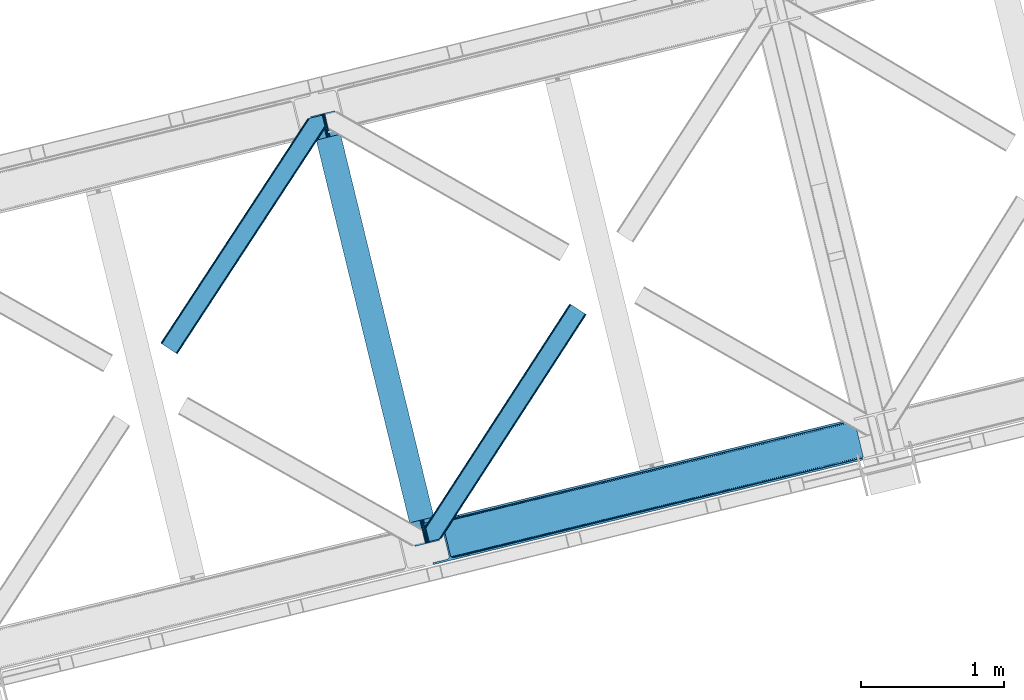
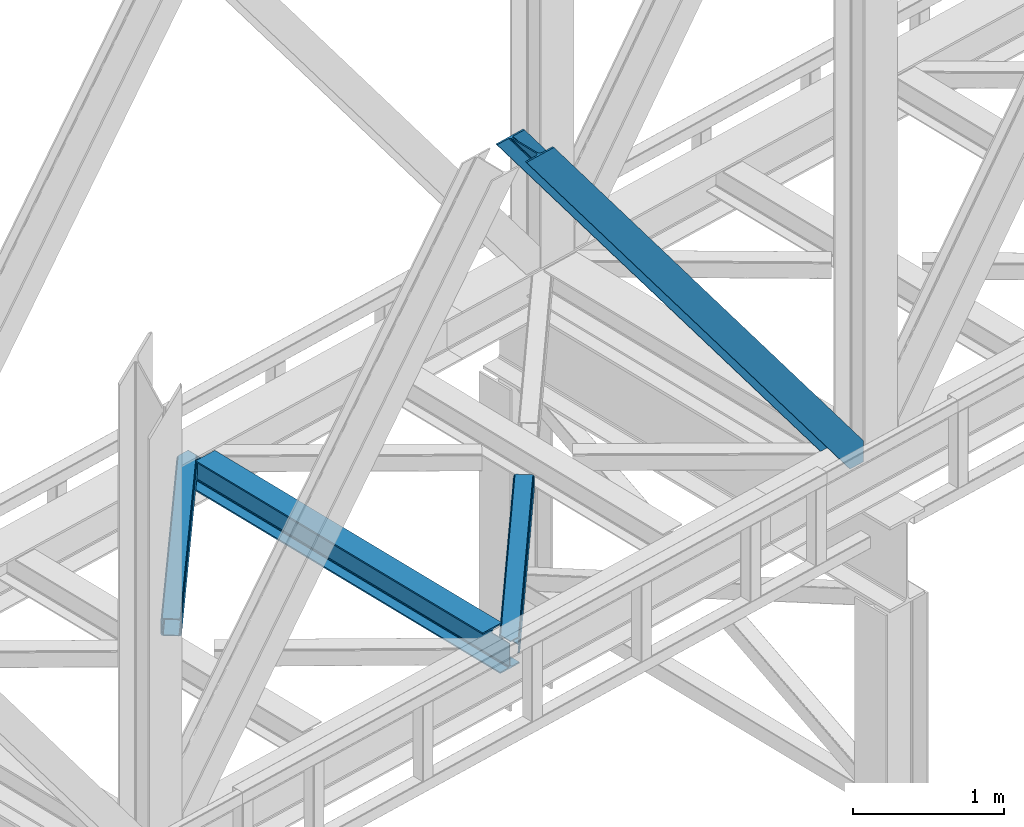
# One storey, part 54 of 92: 3 members, 1 beam.
"""IFC4 building model written with IfcOpenShell, lengths in millimetres."""

from ifc_helpers import new_model, entity, si_unit, converted_unit, derived_unit, direction, frame, origin, place, context, subcontext, project, spatial, triangles, polygons, material, type_object, element, save


model = new_model("IFC4")

# Units and contexts
model_context = context("Model", 3, precision=0.01, world=origin(), true_north=direction((6.12303176911189e-17, 1.0)))
plan_context = context("Plan", 3, precision=0.01, world=origin(), true_north=direction((6.12303176911189e-17, 1.0)))
body_context = subcontext(model_context, "Body", "Model", "MODEL_VIEW")
ifc_project = project(units=[si_unit("LENGTHUNIT", "METRE", prefix="MILLI"), si_unit("AREAUNIT", "SQUARE_METRE"), si_unit("VOLUMEUNIT", "CUBIC_METRE"), converted_unit("PLANEANGLEUNIT", "DEGREE", entity("IfcRatioMeasure", 0.0174532925199433), si_unit("PLANEANGLEUNIT", "RADIAN"), dimensions=[0, 0, 0, 0, 0, 0, 0]), si_unit("MASSUNIT", "GRAM", prefix="KILO"), derived_unit("MASSDENSITYUNIT", [(si_unit("MASSUNIT", "GRAM", prefix="KILO"), 1), (si_unit("LENGTHUNIT", "METRE"), -3)]), derived_unit("MOMENTOFINERTIAUNIT", [(si_unit("LENGTHUNIT", "METRE"), 4)]), si_unit("TIMEUNIT", "SECOND"), si_unit("FREQUENCYUNIT", "HERTZ"), si_unit("THERMODYNAMICTEMPERATUREUNIT", "DEGREE_CELSIUS"), derived_unit("THERMALTRANSMITTANCEUNIT", [(si_unit("MASSUNIT", "GRAM", prefix="KILO"), 1), (si_unit("THERMODYNAMICTEMPERATUREUNIT", "KELVIN"), -1), (si_unit("TIMEUNIT", "SECOND"), -3)]), derived_unit("VOLUMETRICFLOWRATEUNIT", [(si_unit("LENGTHUNIT", "METRE"), 3), (si_unit("TIMEUNIT", "SECOND"), -1)]), derived_unit("MASSFLOWRATEUNIT", [(si_unit("MASSUNIT", "GRAM", prefix="KILO"), 1), (si_unit("TIMEUNIT", "SECOND"), -1)]), derived_unit("ROTATIONALFREQUENCYUNIT", [(si_unit("TIMEUNIT", "SECOND"), -1)]), si_unit("ELECTRICCURRENTUNIT", "AMPERE"), si_unit("ELECTRICVOLTAGEUNIT", "VOLT"), si_unit("POWERUNIT", "WATT"), si_unit("FORCEUNIT", "NEWTON", prefix="KILO"), si_unit("ILLUMINANCEUNIT", "LUX"), si_unit("LUMINOUSFLUXUNIT", "LUMEN"), si_unit("LUMINOUSINTENSITYUNIT", "CANDELA"), derived_unit("USERDEFINED", [(si_unit("MASSUNIT", "GRAM", prefix="KILO"), -1), (si_unit("LENGTHUNIT", "METRE"), -2), (si_unit("TIMEUNIT", "SECOND"), 3), (si_unit("LUMINOUSFLUXUNIT", "LUMEN"), 1)]), derived_unit("LINEARVELOCITYUNIT", [(si_unit("LENGTHUNIT", "METRE"), 1), (si_unit("TIMEUNIT", "SECOND"), -1)]), si_unit("PRESSUREUNIT", "PASCAL"), derived_unit("USERDEFINED", [(si_unit("LENGTHUNIT", "METRE"), -2), (si_unit("MASSUNIT", "GRAM", prefix="KILO"), 1), (si_unit("TIMEUNIT", "SECOND"), -2)]), derived_unit("LINEARFORCEUNIT", [(si_unit("MASSUNIT", "GRAM", prefix="KILO"), 1), (si_unit("LENGTHUNIT", "METRE"), 1), (si_unit("TIMEUNIT", "SECOND"), -2), (si_unit("LENGTHUNIT", "METRE"), -1)]), derived_unit("PLANARFORCEUNIT", [(si_unit("MASSUNIT", "GRAM", prefix="KILO"), 1), (si_unit("LENGTHUNIT", "METRE"), 1), (si_unit("TIMEUNIT", "SECOND"), -2), (si_unit("LENGTHUNIT", "METRE"), -2)])], contexts=[model_context, plan_context])

# Site, building, storey
site_placement = place(None, origin())
site = spatial("IfcSite", under=ifc_project, at=site_placement, CompositionType="ELEMENT")
building_placement = place(site_placement, origin())
building = spatial("IfcBuilding", under=site, at=building_placement, CompositionType="ELEMENT")
storey_placement = place(building_placement, frame((0.0, 0.0, 15900.0)))
storey = spatial("IfcBuildingStorey", under=building, at=storey_placement, Name="05", CompositionType="ELEMENT", Elevation=15900.0)

# Beam
ifc_material = material(Name="Metal painted (White)")
beam_type = type_object("IfcBeamType", PredefinedType="BEAM")
beam_placement = place(storey_placement, frame((-33403.98, 9644.13, 3441.0)))
element("IfcBeam", 1, at=beam_placement, inside=storey, type_object=beam_type, material=ifc_material, ObjectType="Steel Beam", PredefinedType="BEAM", context=body_context, shape_type="Tessellation", body=[
    polygons([(900.98534618944, 41.4445662733092, 11.000000000004), (900.98534618944, 41.4445662733092, 2.16573425859679e-12), (170.021610174761, 3040.13999372697, 2.16573425859679e-12), (170.021610174761, 3040.13999372697, 11.000000000004), (834.919806235814, 25.3403919499667, 11.000000000004), (103.956070221144, 3024.03581940363, 11.000000000004), (828.971056214522, 23.8903211957407, 12.2179274798217), (98.0073201998513, 3022.5857486494, 12.2179274798217), (823.927949458409, 22.6610105689183, 15.6862915010235), (92.964213443734, 3021.35643802258, 15.6862915010235), (820.558253255237, 21.8396114687119, 20.8770650821657), (89.5945172405668, 3020.53503892237, 20.8770650821657), (819.374973305552, 21.5511744621206, 27.0000000000047), (88.4112372908723, 3020.24660191578, 27.0000000000047), (81.6103728838844, 3018.58881926485, 27.0000000000025), (81.6103728838801, 3018.58881926485, 203.000000000006), (88.4112372908723, 3020.24660191578, 203.000000000006), (0.0, 2998.69542745366, 2.16573425859679e-12), (0.0, 2998.69542745366, 10.9999999999997), (66.0655399536216, 3014.799601777, 11.000000000004), (72.014289974914, 3016.24967253123, 12.2179274798217), (77.0573967310226, 3017.47898315805, 15.6862915010192), (80.4270929342029, 3018.30038225826, 20.8770650821657), (819.374973305552, 21.5511744621206, 203.000000000006), (812.574108898559, 19.8933918111876, 203.000000000006), (812.574108898559, 19.8933918111876, 27.0000000000025), (811.390828948882, 19.6049548045984, 20.8770650821657), (808.021132745702, 18.7835557043887, 15.6862915010192), (802.978025989593, 17.5542450775685, 12.2179274798217), (797.029275968301, 16.1041743233436, 11.000000000004), (730.963736014679, 0.0, 10.9999999999997), (730.963736014679, 0.0, 2.16573425859679e-12), (779.675212882766, 184.415062601693, 203.069791966819), (128.020401343512, 2857.75452019162, 203.000000000006), (128.243282132663, 2856.8401777572, 203.617301946336), (128.256196377186, 2856.7871977843, 217.000003693143), (779.530009633837, 185.010597404073, 217.000003676718), (779.530880241731, 185.007025963196, 204.00000679514), (772.96491171832, 182.385463974442, 203.006342981529), (772.742064056782, 183.299815969777, 203.617301946336), (772.729149812254, 183.352795942668, 217.000003693143), (121.455336555608, 2855.1293963229, 217.000003676718), (121.454465947714, 2855.13296776377, 204.00000679514), (121.31016635866, 2855.72494066435, 203.076120467494), (121.219536936524, 2856.09673754069, 203.000000000006), (780.713494357868, 185.298194377515, 223.122939328039), (784.082490766539, 186.122464201392, 228.313710402595), (789.125126170563, 187.353708426698, 231.782072735464), (795.073705041271, 188.804481281382, 232.999999602236), (861.139155906794, 204.909021065316, 232.999999283132), (861.137682570357, 204.915065042189, 243.999994005812), (691.11630166644, 163.469558245299, 243.999994827032), (691.117775002877, 163.463514268425, 233.000000104353), (757.183225868401, 179.568054052362, 232.999999785253), (763.132130996726, 181.017488520583, 231.782072861016), (768.175695503862, 182.244921343717, 228.313710479427), (771.546082413602, 183.063487001149, 223.12293937232), (120.271851831576, 2854.84179934946, 223.122939328039), (116.902855422897, 2854.01752952558, 228.313710402595), (111.860220018877, 2852.78628530027, 231.782072735464), (105.911641148165, 2851.33551244559, 232.999999602236), (39.8461902826505, 2835.23097266165, 232.999999283128), (39.8476636190881, 2835.22492868478, 243.999994005812), (209.869044523005, 2876.67043548167, 243.999994827032), (209.867571186567, 2876.67647945855, 233.000000104357), (143.80212032104, 2860.57193967461, 232.999999785253), (137.85321519271, 2859.12250520639, 231.782072861012), (132.809650685579, 2857.89507238325, 228.313710479427), (129.439263775838, 2857.07650672582, 223.12293937232)], [[[1, 2, 3, 4]], [[5, 1, 4, 6]], [[7, 5, 6, 8]], [[9, 7, 8, 10]], [[11, 9, 10, 12]], [[13, 11, 12, 14]], [[15, 16, 17, 14, 12, 10, 8, 6, 4, 3, 18, 19, 20, 21, 22, 23]], [[13, 24, 25, 26, 27, 28, 29, 30, 31, 32, 2, 1, 5, 7, 9, 11]], [[2, 32, 18, 3]], [[32, 31, 19, 18]], [[31, 30, 20, 19]], [[27, 26, 15, 23]], [[28, 27, 23, 22]], [[29, 28, 22, 21]], [[30, 29, 21, 20]], [[33, 24, 13, 14, 17, 34, 35, 36, 37, 38]], [[25, 39, 40, 41, 42, 43, 44, 16, 15, 26]], [[39, 25, 24, 33]], [[45, 34, 17, 16]], [[41, 40, 38, 37, 46, 47, 48, 49, 50, 51, 52, 53, 54, 55, 56, 57]], [[42, 58, 59, 60, 61, 62, 63, 64, 65, 66, 67, 68, 69, 36, 35, 43]], [[46, 37, 36, 69]], [[47, 46, 69, 68]], [[48, 47, 68, 67]], [[49, 48, 67, 66]], [[50, 49, 66, 65]], [[51, 50, 65, 64]], [[52, 51, 64, 63]], [[53, 52, 63, 62]], [[54, 53, 62, 61]], [[55, 54, 61, 60]], [[56, 55, 60, 59]], [[57, 56, 59, 58]], [[41, 57, 58, 42]]], closed=False),
])

# Members
member_type_1 = type_object("IfcMemberType", PredefinedType="BRACE")
member_1_placement = place(storey_placement, frame((-32615.9, 9516.32, 3695.0)))
element("IfcMember", 2, at=member_1_placement, inside=storey, type_object=member_type_1, ObjectType="Steel Vertical Brace", PredefinedType="BRACE", context=body_context, shape_type="Tessellation", body=[
    triangles([(3070.87069702148, 756.345112609863, 0.827856445310317), (3071.52647094726, 755.357963562012, 1.13481445312209), (3070.10562744141, 754.873109436036, 0.0), (3068.17783813476, 762.778440856933, 0.0), (3067.78251342773, 753.546446228027, 7.26932373046657), (3067.78251342773, 753.546446228027, 0.0), (3064.92454833984, 750.387336730957, 0.0), (3063.48277587891, 746.379441833496, 0.0), (3065.2245300293, 750.173396301268, 14.9735046386704), (3064.09204101563, 748.68162689209, 18.377947998044), (3063.67113647461, 742.123887634278, 0.0), (3063.35952758789, 744.487696838378, 30.2981506347642), (3063.478125, 743.106385803223, 41.9881347656228), (3063.68508911133, 746.345722961425, 25.0194030761704), (3063.478125, 743.106385803223, 170.743066406249), (3063.67113647461, 742.123887634278, 170.803527832031), (215.791479492189, 48.9522445678704, 3911.00081176758), (310.560113525389, 72.0531600952145, 3911.00081176758), (192.892877197264, 54.8071197509762, 3911.00081176758), (199.032037353514, 50.2928604125973, 3911.00081176758), (207.07108154297, 48.2371719360344, 3911.00081176758), (189.588427734376, 61.0922012329102, 3911.00081176758), (3066.51282348633, 730.465296936034, 170.803527832031), (313.638995361329, 59.4225357055657, 3911.00081176758), (3066.51282348633, 730.465296936034, 0.0), (2948.45258789062, 701.686820983887, 0.0), (69.8631774902351, 0.0, 3911.00081176758), (2945.37370605469, 714.317445373536, 0.0), (66.7842956542954, 12.6300430297852, 3911.00081176758), (161.552929687499, 35.7309585571293, 3911.00081176758), (3040.14001464844, 737.417198181152, 0.0), (3057.81800537109, 760.25301361084, 0.0), (3057.77847290039, 753.153446960448, 0.0), (179.230920410155, 58.5667739868168, 3911.00081176758), (179.191387939452, 51.4677886962891, 3911.00081176758), (3054.40658569336, 746.321305847168, 0.0), (175.819500732421, 44.6350662231434, 3911.00081176758), (3048.21394042969, 740.794898986816, 0.0), (169.624530029298, 39.1086593627933, 3911.00081176758), (3002.63765258789, 986.625242614746, 0.0), (124.050567626953, 284.939002990723, 3911.00081176758), (2976.43460083008, 998.764036560058, 0.0), (2985.15732421875, 999.480271911621, 0.0), (106.567913818359, 297.794032287597, 3911.00081176758), (97.8475158691399, 297.078959655761, 3911.00081176758), (2993.1963684082, 997.424583435059, 0.0), (114.609283447266, 295.738343811036, 3911.00081176758), (2999.33552856445, 992.909742736816, 0.0), (120.748443603516, 291.223503112793, 3911.00081176758), (3.07888183593604, 273.978044128418, 3911.00081176758), (2881.66829223633, 975.664283752441, 0.0), (2878.58941040039, 988.29490814209, 0.0), (0.0, 286.60750579834, 3911.00081176758), (3012.99748535156, 989.150669860839, 0.0), (134.40807495117, 287.463267517089, 3911.00081176758), (144.014465332031, 306.922544860839, 3911.00081176758), (243.775817871094, 346.030622863769, 3911.00081176758), (152.08606567383, 310.300245666504, 3911.00081176758), (137.821820068359, 301.396138000488, 3911.00081176758), (134.449932861327, 294.563996887207, 3911.00081176758), (246.85469970703, 333.39999847412, 3911.00081176758), (2996.64964599609, 1017.07222137451, 170.803527832031), (2996.64964599609, 1017.07222137451, 0.0), (2999.49133300781, 1005.41363067627, 170.803527832031), (2999.77271118164, 1004.45322418213, 170.743066406249), (2999.77271118164, 1004.45322418213, 41.9881347656228), (2999.49133300781, 1005.41363067627, 0.0), (3008.39776611328, 997.164134216308, 0.0), (3001.28192138672, 1001.54875030518, 0.0), (3004.40731201172, 998.654740905762, 0.0), (3011.07202148438, 997.056001281739, 0.0), (3000.30291137695, 1003.17190704346, 30.2981506347642), (3001.44702758789, 1001.67199859619, 25.0194030761704), (3002.88182373047, 999.78490447998, 18.377947998044), (3004.57474365235, 998.981465148925, 14.9735046386704), (3008.39776611328, 997.164134216308, 7.26932373046657), (3012.55565185547, 997.279243469238, 1.13481445312209), (3012.42775268555, 996.10140838623, 0.827856445310317)], [[1, 2, 3], [3, 4, 1], [5, 6, 3], [7, 6, 5], [8, 7, 9], [9, 10, 8], [11, 12, 13], [11, 8, 14], [14, 12, 11], [13, 15, 16], [16, 11, 13], [10, 14, 8], [5, 9, 7], [3, 2, 5], [17, 18, 15], [15, 13, 17], [1, 19, 5], [19, 20, 10], [10, 9, 19], [9, 5, 19], [13, 12, 21], [21, 17, 13], [14, 20, 12], [14, 10, 20], [20, 21, 12], [5, 2, 1], [1, 4, 19], [22, 19, 4], [16, 15, 18], [23, 16, 24], [18, 24, 16], [23, 25, 16], [11, 16, 25], [24, 26, 23], [24, 27, 26], [26, 25, 23], [28, 26, 27], [27, 29, 28], [29, 30, 28], [31, 28, 30], [32, 33, 34], [35, 34, 33], [33, 36, 35], [37, 35, 36], [36, 38, 37], [39, 37, 38], [38, 31, 39], [30, 39, 31], [40, 32, 34], [34, 41, 40], [42, 43, 44], [44, 45, 42], [43, 46, 47], [47, 44, 43], [46, 48, 49], [49, 47, 46], [48, 40, 41], [41, 49, 48], [45, 50, 51], [51, 42, 45], [52, 51, 50], [50, 53, 52], [4, 54, 22], [55, 22, 54], [41, 34, 55], [37, 39, 21], [30, 27, 24], [29, 27, 30], [39, 30, 17], [34, 35, 19], [35, 37, 20], [47, 56, 44], [53, 45, 57], [45, 44, 58], [53, 50, 45], [47, 49, 59], [49, 41, 60], [55, 34, 22], [17, 21, 39], [19, 35, 20], [21, 20, 37], [19, 22, 34], [24, 17, 30], [24, 18, 17], [58, 44, 56], [59, 49, 60], [55, 60, 41], [59, 56, 47], [58, 57, 45], [57, 58, 61], [57, 52, 53], [52, 57, 62], [63, 52, 62], [64, 62, 57], [65, 64, 61], [57, 61, 64], [61, 58, 65], [66, 65, 58], [64, 67, 63], [63, 62, 64], [32, 40, 54], [46, 43, 67], [42, 52, 63], [51, 52, 42], [43, 42, 63], [40, 48, 68], [48, 46, 69], [36, 11, 38], [26, 31, 25], [31, 38, 25], [26, 28, 31], [36, 33, 8], [33, 32, 6], [8, 11, 36], [54, 40, 68], [67, 69, 46], [63, 67, 43], [48, 69, 70], [70, 68, 48], [71, 54, 68], [32, 54, 4], [8, 33, 7], [33, 6, 7], [11, 25, 38], [32, 4, 6], [3, 6, 4], [67, 72, 73], [65, 66, 64], [67, 64, 66], [66, 72, 67], [69, 74, 75], [69, 73, 74], [70, 75, 76], [76, 77, 71], [71, 68, 76], [76, 68, 70], [75, 70, 69], [73, 69, 67], [60, 78, 76], [76, 59, 60], [76, 75, 59], [74, 59, 75], [78, 77, 76], [54, 78, 60], [60, 55, 54], [73, 59, 74], [59, 73, 72], [56, 59, 72], [72, 66, 56], [58, 56, 66], [77, 78, 71], [54, 71, 78]]),
])
member_type_2 = type_object("IfcMemberType", PredefinedType="BRACE")
member_2_placement = place(storey_placement, frame((-34450.78, 10986.08, 3511.0)))
element("IfcMember", 3, at=member_2_placement, inside=storey, type_object=member_type_2, ObjectType="Steel Horizontal Brace", PredefinedType="BRACE", context=body_context, shape_type="Tessellation", body=[
    triangles([(994.774163818358, 1564.02778930664, 0.0), (1028.82324829101, 1424.34794311523, 0.0), (14.6409667968692, 67.1040435791019, 0.0), (102.486767578121, 9.58662414550781, 0.0), (1.11388549804542, 75.9604797363281, 10.8028289794929), (0.0, 76.6906677246097, 17.5000946044929), (1025.02813110351, 1642.17999572754, 17.5000946044929), (4.28811035156104, 73.8826995849613, 5.12526855468968), (990.476751708979, 1585.8776184082, 9.50058288574292), (990.04654541015, 1584.44747314453, 8.74132690429906), (989.907019042963, 1583.99284973144, 8.50064392089917), (990.762780761717, 1580.48841247559, 5.12526855468968), (1027.30938720703, 1642.73577575684, 10.8702667236357), (1027.78145141601, 1642.85088500977, 9.50058288574292), (992.602203369141, 1572.93654785156, 1.33247680664135), (9.03898315429251, 70.7724243164066, 1.33247680664135), (1025.02813110351, 1642.17999572754, 122.500662231447), (0.0, 76.6906677246097, 122.500662231447), (1026.92103881836, 1642.64159545898, 129.197927856447), (1.11388549804542, 75.9604797363281, 129.197927856447), (1032.31605834961, 1643.95663146973, 134.874325561526), (4.28811035156104, 73.8826995849613, 134.874325561526), (1040.39463500976, 1645.9251159668, 138.667117309571), (9.03898315429251, 70.7724243164066, 138.667117309571), (1049.91963500976, 1648.24706726074, 139.999594116212), (14.6409667968692, 67.1040435791019, 139.999594116212), (994.871832275385, 1567.8519744873, 9.50058288574292), (994.762536621092, 1567.00783996582, 9.29478149414354), (994.648590087891, 1566.15091552734, 9.08781738281323), (994.541619873045, 1565.30678100586, 8.8831787109375), (994.746258544918, 1564.14522399902, 8.50064392089917), (1047.05469360351, 1647.54827270508, 9.50058288574292), (14.8944396972656, 66.9377746582031, 8.3320495605476), (20.4987487792969, 63.2705566406257, 6.99957275390625), (997.043792724609, 1554.7155670166, 6.99957275390625), (10.1458923339815, 70.0480499267578, 12.1260040283232), (1042.27359008789, 1646.38322753906, 12.1260040283232), (1036.87857055664, 1645.06819152832, 17.8035644531265), (1034.98333740234, 1644.60659179688, 24.4996673583992), (6.96934204101126, 72.1258300781246, 17.8035644531265), (5.85545654296584, 72.8560180664063, 24.4996673583992), (1026.55361938477, 1433.66016540527, 6.99957275390625), (96.6289855957002, 13.4212738037113, 6.99957275390625), (1028.71860351562, 1424.77698669434, 8.41343994140698), (1032.83463134765, 1407.88615722656, 5.12526855468968), (1033.6903930664, 1404.38288269043, 8.50064392089917), (1030.99520874023, 1415.43918457031, 1.33247680664135), (1034.98333740234, 1644.60659179688, 115.501089477541), (5.85545654296584, 72.8560180664063, 115.501089477541), (1050.34751586914, 1648.35171203613, 131.667544555665), (1059.87251586914, 1650.67366333008, 133.000021362306), (20.4987487792969, 63.2705566406257, 133.000021362306), (14.8944396972656, 66.9377746582031, 131.667544555665), (1042.27359008789, 1646.38322753906, 127.87475280762), (10.1458923339815, 70.0480499267578, 127.87475280762), (1036.87857055664, 1645.06819152832, 122.196029663086), (6.96934204101126, 72.1258300781246, 122.196029663086), (1128.10788574218, 1667.30636901856, 139.999594116212), (1128.10788574218, 1667.30636901856, 133.000021362306), (1144.33015136718, 1600.75810546875, 139.999594116212), (102.486767578121, 9.58662414550781, 139.999594116212), (1142.06052246093, 1610.07032775879, 133.000021362306), (96.6289855957002, 13.4212738037113, 133.000021362306), (1146.5021118164, 1591.84934692383, 138.667117309571), (108.088751220697, 5.91824340820313, 138.667117309571), (1148.34385986328, 1584.2974822998, 134.874325561526), (112.839624023436, 2.80796813964844, 134.874325561526), (1149.57401733398, 1579.2501159668, 129.197927856447), (116.011523437497, 0.730187988281614, 129.197927856447), (1150.00422363281, 1577.47813110351, 122.500662231447), (117.125408935543, 0.0, 122.500662231447), (1150.00422363281, 1577.47813110351, 17.5000946044929), (117.125408935543, 0.0, 17.5000946044929), (106.981842041016, 6.64261779785193, 127.87475280762), (110.156066894531, 4.5648376464851, 122.196029663086), (111.269952392577, 3.83464965820349, 115.501089477541), (102.233294677731, 9.75289306640661, 131.667544555665), (116.011523437497, 0.730187988281614, 10.8028289794929), (106.981842041016, 6.64261779785193, 12.1260040283232), (112.839624023436, 2.80796813964844, 5.12526855468968), (111.269952392577, 3.83464965820349, 24.4996673583992), (110.156066894531, 4.5648376464851, 17.8035644531265), (108.088751220697, 5.91824340820313, 1.33247680664135), (102.233294677731, 9.75289306640661, 8.3320495605476), (1147.30206298828, 1588.56233825684, 122.196029663086), (1147.73459472656, 1586.79035339356, 115.501089477541), (1146.07190551757, 1593.60854187012, 127.87475280762), (1144.23248291016, 1601.16156921387, 131.667544555665), (1147.73459472656, 1586.79035339356, 24.4996673583992), (1147.21369628906, 1588.92510681152, 17.869839477542), (1149.994921875, 1577.51650085449, 16.5001556396492), (1147.10672607421, 1589.36577758789, 16.5001556396492), (1145.27660522461, 1573.10863037109, 10.8714294433594), (1034.62056884765, 1404.788671875, 9.50058288574292), (1144.12783813477, 1572.03544006348, 9.50058288574292), (1142.79303588867, 1588.59838256836, 12.1260040283232), (1030.22548828125, 1422.8143157959, 9.50058288574292), (1029.19764404296, 1423.6724029541, 8.80643920898729), (1139.73275756836, 1590.06108398438, 9.50058288574292)], [[1, 2, 3], [4, 3, 2], [5, 6, 7], [8, 9, 10], [11, 12, 8], [5, 13, 9], [9, 8, 5], [13, 14, 9], [15, 1, 16], [3, 16, 1], [12, 15, 8], [16, 8, 15], [7, 13, 5], [17, 7, 6], [6, 18, 17], [19, 17, 20], [18, 20, 17], [21, 19, 22], [20, 22, 19], [23, 21, 24], [22, 24, 21], [25, 23, 26], [24, 26, 23], [27, 28, 9], [28, 29, 10], [29, 30, 10], [30, 31, 11], [14, 32, 27], [27, 9, 14], [33, 34, 35], [36, 33, 31], [31, 30, 36], [28, 36, 29], [28, 27, 36], [36, 30, 29], [32, 37, 27], [36, 27, 37], [35, 31, 33], [38, 39, 40], [41, 40, 39], [37, 38, 36], [40, 36, 38], [42, 35, 34], [34, 43, 42], [1, 35, 42], [31, 12, 11], [1, 31, 35], [31, 15, 12], [31, 1, 15], [2, 1, 42], [44, 2, 42], [45, 44, 46], [44, 47, 2], [44, 45, 47], [39, 48, 41], [49, 41, 48], [50, 51, 52], [52, 53, 50], [54, 50, 53], [53, 55, 54], [56, 54, 55], [55, 57, 56], [48, 56, 57], [57, 49, 48], [56, 17, 19], [50, 23, 25], [58, 51, 25], [51, 58, 59], [51, 50, 25], [54, 23, 50], [54, 56, 21], [21, 23, 54], [19, 21, 56], [39, 7, 17], [37, 14, 38], [56, 48, 17], [37, 32, 14], [39, 38, 7], [48, 39, 17], [13, 7, 38], [38, 14, 13], [60, 25, 61], [25, 60, 58], [26, 61, 25], [51, 62, 63], [51, 59, 62], [63, 52, 51], [64, 60, 61], [61, 65, 64], [66, 64, 65], [65, 67, 66], [68, 66, 67], [67, 69, 68], [70, 68, 69], [69, 71, 70], [72, 70, 71], [71, 73, 72], [69, 74, 75], [76, 73, 71], [69, 75, 71], [69, 67, 74], [75, 76, 71], [74, 67, 65], [63, 61, 26], [61, 77, 65], [77, 61, 63], [77, 74, 65], [78, 79, 80], [81, 73, 76], [73, 82, 78], [82, 73, 81], [78, 82, 79], [4, 43, 3], [83, 80, 79], [79, 84, 83], [84, 43, 4], [4, 83, 84], [55, 24, 22], [26, 52, 63], [26, 53, 52], [53, 26, 24], [55, 53, 24], [49, 18, 6], [20, 57, 55], [22, 20, 55], [57, 20, 18], [49, 57, 18], [16, 36, 8], [3, 43, 34], [34, 33, 3], [33, 36, 16], [16, 3, 33], [5, 8, 36], [6, 41, 49], [40, 6, 5], [6, 40, 41], [40, 5, 36], [85, 86, 75], [76, 75, 86], [87, 85, 74], [75, 74, 85], [88, 87, 77], [74, 77, 87], [62, 88, 63], [77, 63, 88], [86, 89, 81], [81, 76, 86], [90, 91, 92], [70, 72, 89], [72, 90, 89], [89, 86, 70], [72, 91, 90], [85, 70, 86], [68, 70, 85], [66, 85, 87], [85, 66, 68], [87, 64, 66], [88, 64, 87], [88, 62, 60], [88, 60, 64], [62, 58, 60], [62, 59, 58], [73, 78, 93], [93, 72, 73], [94, 93, 78], [94, 95, 93], [80, 45, 46], [46, 78, 80], [46, 94, 78], [47, 45, 83], [80, 83, 45], [2, 47, 4], [83, 4, 47], [93, 91, 72], [82, 81, 89], [82, 92, 96], [82, 90, 92], [84, 97, 98], [79, 96, 97], [97, 84, 79], [96, 99, 97], [43, 84, 44], [44, 42, 43], [96, 79, 82], [89, 90, 82], [96, 91, 93], [96, 92, 91], [96, 95, 99], [93, 95, 96], [99, 95, 97], [94, 97, 95]]),
])
member_type_3 = type_object("IfcMemberType", PredefinedType="BRACE")
member_3_placement = place(storey_placement, frame((-32601.72, 9677.15, 3510.06)))
element("IfcMember", 4, at=member_3_placement, inside=storey, type_object=member_type_3, ObjectType="Steel Horizontal Brace", PredefinedType="BRACE", context=body_context, shape_type="Tessellation", body=[
    triangles([(1021.07255859375, 1650.67133789062, 0.387185668947495), (1109.18811035156, 1593.56668395996, 0.387185668947495), (114.153497314452, 251.255593872071, 0.0209289550803078), (148.353735351564, 110.958343505859, 0.0), (1007.50594482422, 1659.46266174316, 11.1900146484404), (0.523223876953125, 105.142419433594, 10.85166320801), (0.0, 107.29112548828, 17.4814910888672), (108.346874999999, 270.855560302734, 9.46221313476781), (0.634844970703853, 104.692446899413, 9.46221313476781), (1010.68947143555, 1657.39999694824, 5.51245422363354), (110.123510742189, 267.789468383789, 5.14968566894822), (109.277050781249, 271.259024047851, 8.46227416992406), (108.646856689455, 271.243908691406, 9.38547363281396), (1015.454296875, 1654.31297607422, 1.71849975586156), (111.972235107423, 260.203884887695, 1.35456848144531), (1006.38740844727, 1660.18587341309, 17.8872802734404), (1006.37345581055, 1660.16610717773, 122.886685180667), (0.0, 107.29112548828, 122.482058715821), (1021.05860595703, 1650.64575805664, 140.385617065433), (1015.43801879883, 1654.28855895996, 139.055465698242), (3.51838989257885, 92.8559600830067, 138.646188354494), (5.69965209961083, 83.9088317871083, 139.976339721681), (1010.67319335938, 1657.37674255371, 135.260348510743), (1.66966552734448, 100.442706298827, 134.853396606446), (1007.4919921875, 1659.44057006836, 129.583950805667), (0.434857177733647, 105.511001586914, 129.17699890137), (112.781488037108, 252.660159301757, 9.46221313476781), (5.05317993164135, 86.5644836425781, 9.46221313476781), (1021.32603149414, 1650.50506896973, 8.7192352294951), (113.111700439455, 252.928747558593, 9.38547363281396), (113.818634033203, 251.768353271484, 8.76806945800854), (1016.56353149414, 1653.59208984375, 12.5120269775398), (3.95092163085792, 91.089788818359, 12.1039123535156), (1026.9489440918, 1646.86343078613, 7.38675842285375), (114.255816650391, 250.833526611328, 8.40646362304688), (116.434753417969, 241.902676391601, 7.01933898925927), (1013.38000488281, 1655.65475463867, 18.1895874023467), (2.71378784179615, 96.1580841064442, 17.7826354980498), (1012.25914306641, 1656.37680358887, 24.8868530273467), (2.28125610351708, 97.9382080078121, 24.4799011230498), (1103.31172485352, 1597.372265625, 7.38675842285375), (146.072479248047, 120.311260986327, 7.00073547363354), (150.534997558592, 102.010052490234, 1.33015136719041), (148.353735351564, 110.953692626952, 8.46227416992406), (152.383721923827, 94.4244689941406, 5.1229431152351), (153.234832763672, 90.9316589355458, 8.46227416992406), (1012.24984130859, 1656.36052551269, 115.887112426761), (2.28125610351708, 97.9382080078121, 115.480160522464), (1013.36837768555, 1655.63498840332, 122.584378051761), (2.71378784179615, 96.1580841064442, 122.177426147464), (1016.54957885742, 1653.57116088867, 128.260775756837), (3.95092163085792, 91.089788818359, 127.85382385254), (1021.31207885742, 1650.48297729492, 132.053567504885), (5.79964599609229, 83.5030426025387, 131.644290161134), (1026.93266601563, 1646.8401763916, 133.386044311526), (7.98090820312427, 74.554751586913, 132.976766967775), (26.1542175292961, 0.0, 139.964712524416), (26.1542175292961, 0.0, 132.965139770509), (1109.17183227539, 1593.54110412598, 140.385617065433), (85.8808044433608, 14.5589950561516, 139.974014282227), (1103.30009765625, 1597.3501739502, 133.386044311526), (75.9744323730483, 12.1440261840817, 132.972116088869), (1123.85930786133, 1584.02656860351, 122.886685180667), (1122.74077148438, 1584.75094299316, 129.583950805667), (110.646734619142, 20.5958358764638, 122.477407836916), (108.760803222656, 20.1359802246097, 129.174673461916), (1119.55724487305, 1586.81244506836, 135.260348510743), (103.391363525392, 18.8279205322269, 134.851071166995), (1114.79241943359, 1589.89946594238, 139.055465698242), (95.3569702148452, 16.8693191528309, 138.64386291504), (1123.87093505859, 1584.04633483887, 17.8872802734404), (110.646734619142, 20.5958358764638, 17.478002929689), (1122.75472412109, 1584.77187194824, 11.1900146484404), (1113.69713745117, 1590.64244384766, 12.5120269775398), (1116.8806640625, 1588.57861633301, 18.1895874023467), (1117.996875, 1587.85191650391, 24.8868530273467), (1119.57119750977, 1586.83686218262, 5.51245422363354), (1114.80869750976, 1589.92504577637, 1.71849975586156), (1108.93231201172, 1593.73062744141, 8.7192352294951), (1113.68318481445, 1590.62035217285, 128.260775756837), (1117.98524780274, 1587.83563842773, 115.887112426761), (1116.86903686524, 1588.55885009766, 122.584378051761), (1108.918359375, 1593.70737304687, 132.053567504885), (85.4505981445327, 14.454350280761, 131.641964721683), (93.4849914550796, 16.4129516601552, 127.849172973634), (98.8521057128892, 17.721011352538, 122.172775268555), (100.74036254883, 18.1808670043938, 115.477835083009), (100.74036254883, 18.1808670043938, 24.4764129638679), (93.4849914550796, 16.4129516601552, 12.1015869140647), (107.895739746094, 19.9255279541012, 9.46221313476781), (98.8521057128892, 17.721011352538, 17.7791473388679), (88.6992370605476, 15.2461624145508, 9.46221313476781), (108.372454833985, 20.0412185668938, 10.8481750488281), (152.669750976562, 89.0306121826161, 9.46221313476781), (153.097631835939, 90.4723846435536, 8.7041198730476), (148.239788818359, 107.195782470702, 9.46221313476781), (148.563024902345, 109.771206665038, 8.84480895996239), (148.458380126955, 108.917770385742, 9.04944763183812), (148.349084472655, 108.050381469726, 9.25757446289208)], [[1, 2, 3], [4, 3, 2], [5, 6, 7], [8, 6, 5], [8, 9, 6], [10, 11, 12], [12, 5, 10], [12, 13, 5], [10, 14, 11], [15, 11, 14], [14, 1, 15], [3, 15, 1], [7, 16, 5], [17, 16, 18], [7, 18, 16], [19, 20, 21], [21, 22, 19], [20, 23, 24], [24, 21, 20], [23, 25, 26], [26, 24, 23], [25, 17, 18], [18, 26, 25], [8, 27, 9], [28, 9, 27], [29, 30, 31], [32, 33, 27], [27, 29, 32], [33, 28, 27], [34, 29, 35], [35, 36, 34], [32, 37, 38], [38, 33, 32], [37, 39, 40], [40, 38, 37], [41, 34, 36], [36, 42, 41], [36, 3, 42], [15, 35, 11], [35, 15, 3], [11, 35, 12], [3, 36, 35], [42, 3, 4], [43, 44, 4], [44, 43, 45], [4, 44, 42], [45, 46, 44], [39, 47, 48], [48, 40, 39], [47, 49, 48], [50, 48, 49], [49, 51, 50], [52, 50, 51], [51, 53, 52], [54, 52, 53], [53, 55, 54], [56, 54, 55], [52, 24, 50], [54, 56, 22], [56, 57, 22], [56, 58, 57], [21, 54, 22], [52, 21, 24], [33, 9, 28], [52, 54, 21], [7, 40, 48], [48, 50, 18], [18, 7, 48], [24, 26, 50], [50, 26, 18], [7, 38, 40], [38, 9, 33], [9, 38, 6], [7, 6, 38], [59, 22, 60], [59, 19, 22], [22, 57, 60], [61, 56, 55], [56, 61, 62], [58, 56, 62], [63, 64, 65], [66, 65, 64], [64, 67, 66], [68, 66, 67], [67, 69, 68], [70, 68, 69], [69, 59, 70], [60, 70, 59], [71, 63, 65], [65, 72, 71], [73, 74, 75], [76, 63, 71], [73, 75, 71], [73, 77, 74], [75, 76, 71], [74, 77, 78], [41, 2, 1], [2, 79, 78], [79, 2, 41], [79, 74, 78], [64, 80, 67], [81, 63, 76], [63, 82, 64], [82, 63, 81], [64, 82, 80], [59, 61, 19], [69, 67, 80], [80, 83, 69], [83, 61, 59], [59, 69, 83], [32, 14, 10], [1, 34, 41], [1, 29, 34], [29, 1, 14], [32, 29, 14], [39, 16, 17], [5, 37, 32], [10, 5, 32], [37, 5, 16], [39, 37, 16], [20, 51, 23], [19, 61, 55], [55, 53, 19], [53, 51, 20], [20, 19, 53], [25, 23, 51], [17, 47, 39], [49, 17, 25], [17, 49, 47], [49, 25, 51], [61, 83, 84], [84, 62, 61], [83, 80, 85], [85, 84, 83], [80, 82, 86], [86, 85, 80], [82, 81, 87], [87, 86, 82], [81, 76, 87], [88, 87, 76], [86, 65, 66], [84, 70, 60], [62, 57, 58], [60, 62, 84], [62, 60, 57], [85, 70, 84], [85, 86, 68], [68, 70, 85], [66, 68, 86], [72, 65, 87], [89, 90, 91], [86, 87, 65], [89, 92, 90], [88, 91, 72], [88, 72, 87], [93, 72, 91], [91, 90, 93], [73, 71, 72], [77, 94, 95], [46, 45, 77], [73, 93, 94], [94, 77, 73], [93, 90, 94], [2, 78, 4], [43, 4, 78], [78, 77, 43], [45, 43, 77], [72, 93, 73], [79, 41, 42], [89, 74, 96], [74, 79, 44], [44, 97, 74], [74, 98, 99], [98, 74, 97], [99, 96, 74], [96, 92, 89], [42, 44, 79], [76, 75, 88], [91, 88, 75], [75, 74, 91], [89, 91, 74], [96, 99, 94], [99, 98, 95], [98, 97, 95], [97, 44, 46], [96, 94, 90], [90, 92, 96]]),
])

save(model, "model.ifc")
